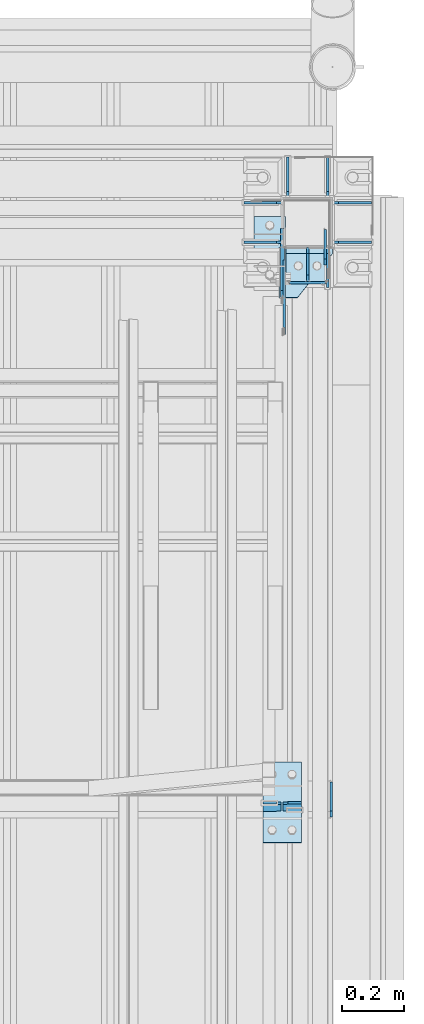
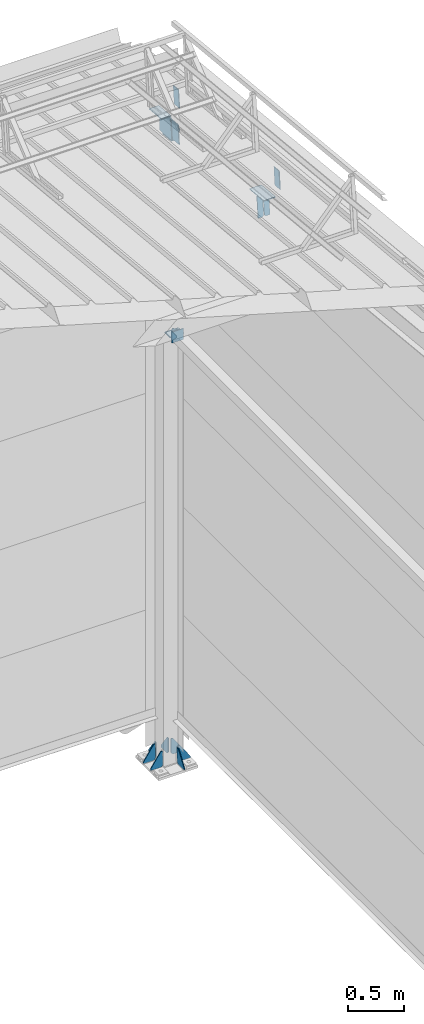
# One storey, part 167 of 709: 21 plates, 5 elements without a shape of their own.
"""IFC4 building model written with IfcOpenShell, lengths in millimetres."""

from ifc_helpers import new_model, si_unit, direction, frame, origin_with_axes, place, context, subcontext, project, spatial, line, indexed_curve, outline, extrude, material, element, aggregate, save


model = new_model("IFC4")

# Units and contexts
model_context = context("Model", 3, precision=0.2, world=origin_with_axes(), true_north=direction((0.0, 1.0)))
body_context = subcontext(model_context, "Body", "Model", "MODEL_VIEW")
ifc_project = project(units=[si_unit("LENGTHUNIT", "METRE", prefix="MILLI"), si_unit("AREAUNIT", "SQUARE_METRE"), si_unit("VOLUMEUNIT", "CUBIC_METRE"), si_unit("MASSUNIT", "GRAM", prefix="KILO"), si_unit("TIMEUNIT", "SECOND"), si_unit("PLANEANGLEUNIT", "RADIAN"), si_unit("SOLIDANGLEUNIT", "STERADIAN"), si_unit("THERMODYNAMICTEMPERATUREUNIT", "DEGREE_CELSIUS"), si_unit("LUMINOUSINTENSITYUNIT", "LUMEN")], contexts=[model_context])

# Site, building, storey
site_placement = place(None, origin_with_axes())
site = spatial("IfcSite", under=ifc_project, at=site_placement, CompositionType="ELEMENT")
building_placement = place(site_placement, origin_with_axes())
building = spatial("IfcBuilding", under=site, at=building_placement, Name="Undefined", CompositionType="ELEMENT")
storey_placement = place(building_placement, origin_with_axes())
storey = spatial("IfcBuildingStorey", under=building, at=storey_placement, Name="Undefined", CompositionType="ELEMENT", Elevation=0.0)

# Assembly, plates
assembly_1_placement = place(storey_placement, frame((49920.0, 21920.0, -200.0), z_axis=(0.0, -1.0, 0.0), x_axis=(0.0, 0.0, 1.0)))
assembly_1 = element("IfcElementAssembly", 1, at=assembly_1_placement, inside=storey)
ifc_material = material(Name="C355-6", Category="STEEL")
plate_1_placement = place(assembly_1_placement, frame((4798.0, 0.0, 180.0), z_axis=(0.0, -1.0, 0.0), x_axis=(-1.0, 0.0, 0.0)))
plate_1 = element("IfcPlate", 2, at=plate_1_placement, material=ifc_material, ObjectType="499", context=body_context, shape_type="SolidModel", body=[
    extrude(outline(indexed_curve([(0.0, 0.0), (20.0, 0.0), (100.0, 80.0), (100.0, 100.0), (0.0, 100.0)], segments=[line(1, 2, 3, 4, 5, 1)])), frame((0.0, 0.0, 4.0), z_axis=(0.0, 0.0, 1.0), x_axis=(1.0, 0.0, 0.0)), (0.0, 0.0, -1.0), 8.0),
])
plate_2_placement = place(assembly_1_placement, frame((4802.0, -70.0, 80.0), z_axis=(1.0, 0.0, 0.0), x_axis=(0.0, 1.0, 0.0)))
plate_2 = element("IfcPlate", 3, at=plate_2_placement, material=ifc_material, ObjectType="504", context=body_context, shape_type="SolidModel", body=[
    extrude(outline(indexed_curve([(0.0, 0.0), (140.0, 0.0), (140.0, 100.0), (0.0, 100.0)], segments=[line(1, 2, 3, 4, 1)])), frame((0.0, 0.0, 4.0), z_axis=(0.0, 0.0, 1.0), x_axis=(1.0, 0.0, 0.0)), (0.0, 0.0, -1.0), 8.0),
])
plate_3_placement = place(assembly_1_placement, frame((25.0, -64.0, 80.0), z_axis=(0.0, -1.0, 0.0), x_axis=(1.0, 0.0, 0.0)))
plate_3 = element("IfcPlate", 4, at=plate_3_placement, material=ifc_material, ObjectType="430", context=body_context, shape_type="SolidModel", body=[
    extrude(outline(indexed_curve([(0.0, 20.0), (20.0, 0.0), (175.0, 0.0), (175.0, 20.0), (20.0, 130.0), (0.0, 130.0)], segments=[line(1, 2, 3, 4, 5, 6, 1)])), frame((0.0, 0.0, 4.0), z_axis=(0.0, 0.0, 1.0), x_axis=(1.0, 0.0, 0.0)), (0.0, 0.0, -1.0), 8.0),
])
plate_4_placement = place(assembly_1_placement, frame((25.0, 64.0, -80.0), z_axis=(0.0, 1.0, 0.0), x_axis=(1.0, 0.0, 0.0)))
plate_4 = element("IfcPlate", 5, at=plate_4_placement, material=ifc_material, ObjectType="430", context=body_context, shape_type="SolidModel", body=[
    extrude(outline(indexed_curve([(0.0, 20.0), (20.0, 0.0), (175.0, 0.0), (175.0, 20.0), (20.0, 130.0), (0.0, 130.0)], segments=[line(1, 2, 3, 4, 5, 6, 1)])), frame((0.0, 0.0, 4.0), z_axis=(0.0, 0.0, 1.0), x_axis=(1.0, 0.0, 0.0)), (0.0, 0.0, -1.0), 8.0),
])
plate_5_placement = place(assembly_1_placement, frame((25.0, 205.0, 64.0), z_axis=(0.0, 0.0, 1.0), x_axis=(0.0, -1.0, 0.0)))
plate_5 = element("IfcPlate", 6, at=plate_5_placement, material=ifc_material, ObjectType="431", context=body_context, shape_type="SolidModel", body=[
    extrude(outline(indexed_curve([(0.0, 0.0), (105.0, 0.0), (125.0, 20.0), (125.0, 175.0), (105.0, 175.0), (0.0, 20.0)], segments=[line(1, 2, 3, 4, 5, 6, 1)])), frame((0.0, 0.0, 4.0), z_axis=(0.0, 0.0, 1.0), x_axis=(1.0, 0.0, 0.0)), (0.0, 0.0, -1.0), 8.0),
])
plate_6_placement = place(assembly_1_placement, frame((25.0, -80.0, 64.0), z_axis=(0.0, 0.0, 1.0), x_axis=(0.0, -1.0, 0.0)))
plate_6 = element("IfcPlate", 7, at=plate_6_placement, material=ifc_material, ObjectType="431", context=body_context, shape_type="SolidModel", body=[
    extrude(outline(indexed_curve([(0.0, 20.0), (20.0, 0.0), (125.0, 0.0), (125.0, 20.0), (20.0, 175.0), (0.0, 175.0)], segments=[line(1, 2, 3, 4, 5, 6, 1)])), frame((0.0, 0.0, 4.0), z_axis=(0.0, 0.0, 1.0), x_axis=(1.0, 0.0, 0.0)), (0.0, 0.0, -1.0), 8.0),
])
plate_7_placement = place(assembly_1_placement, frame((25.0, 205.0, -64.0), z_axis=(0.0, 0.0, 1.0), x_axis=(0.0, -1.0, 0.0)))
plate_7 = element("IfcPlate", 8, at=plate_7_placement, material=ifc_material, ObjectType="431", context=body_context, shape_type="SolidModel", body=[
    extrude(outline(indexed_curve([(0.0, 0.0), (105.0, 0.0), (125.0, 20.0), (125.0, 175.0), (105.0, 175.0), (0.0, 20.0)], segments=[line(1, 2, 3, 4, 5, 6, 1)])), frame((0.0, 0.0, 4.0), z_axis=(0.0, 0.0, 1.0), x_axis=(1.0, 0.0, 0.0)), (0.0, 0.0, -1.0), 8.0),
])
plate_8_placement = place(assembly_1_placement, frame((25.0, -64.0, -80.0), z_axis=(0.0, 1.0, 0.0), x_axis=(1.0, 0.0, 0.0)))
plate_8 = element("IfcPlate", 9, at=plate_8_placement, material=ifc_material, ObjectType="430", context=body_context, shape_type="SolidModel", body=[
    extrude(outline(indexed_curve([(0.0, 20.0), (20.0, 0.0), (175.0, 0.0), (175.0, 20.0), (20.0, 130.0), (0.0, 130.0)], segments=[line(1, 2, 3, 4, 5, 6, 1)])), frame((0.0, 0.0, 4.0), z_axis=(0.0, 0.0, 1.0), x_axis=(1.0, 0.0, 0.0)), (0.0, 0.0, -1.0), 8.0),
])
plate_9_placement = place(assembly_1_placement, frame((25.0, -80.0, -64.0), z_axis=(0.0, 0.0, 1.0), x_axis=(0.0, -1.0, 0.0)))
plate_9 = element("IfcPlate", 10, at=plate_9_placement, material=ifc_material, ObjectType="431", context=body_context, shape_type="SolidModel", body=[
    extrude(outline(indexed_curve([(0.0, 20.0), (20.0, 0.0), (125.0, 0.0), (125.0, 20.0), (20.0, 175.0), (0.0, 175.0)], segments=[line(1, 2, 3, 4, 5, 6, 1)])), frame((0.0, 0.0, 4.0), z_axis=(0.0, 0.0, 1.0), x_axis=(1.0, 0.0, 0.0)), (0.0, 0.0, -1.0), 8.0),
])
plate_10_placement = place(assembly_1_placement, frame((7241.79623, 81.0, 218.70769), z_axis=(0.0, -1.0, 0.0), x_axis=(-0.9950371902, 0.0, 0.099503719)))
plate_10 = element("IfcPlate", 11, at=plate_10_placement, material=ifc_material, ObjectType="455", context=body_context, shape_type="SolidModel", body=[
    extrude(outline(indexed_curve([(0.0, 0.0), (232.0397, 0.0), (232.0397, 162.60347), (226.06948, 222.3057), (0.0, 199.69876)], segments=[line(1, 2, 3, 4, 5, 1)])), frame((0.0, 0.0, 6.0), z_axis=(0.0, 0.0, 1.0), x_axis=(1.0, 0.0, 0.0)), (0.0, 0.0, -1.0), 12.0),
])
plate_11_placement = place(assembly_1_placement, frame((7006.92795, 92.0, 242.19452), z_axis=(-0.9950371902, 0.0, 0.099503719), x_axis=(-0.099503719, 0.0, -0.9950371902)))
plate_11 = element("IfcPlate", 12, at=plate_11_placement, material=ifc_material, ObjectType="456", context=body_context, shape_type="SolidModel", body=[
    extrude(outline(indexed_curve([(0.0, 0.0), (162.60347, 0.0), (162.60347, 172.0), (142.60347, 172.0), (0.0, 59.5)], segments=[line(1, 2, 3, 4, 5, 1)])), frame((0.0, 0.0, 4.0), z_axis=(0.0, 0.0, 1.0), x_axis=(1.0, 0.0, 0.0)), (0.0, 0.0, -1.0), 8.0),
])
aggregate(assembly_1, [plate_1, plate_2, plate_3, plate_4, plate_5, plate_6, plate_7, plate_8, plate_9, plate_10, plate_11])

assembly_2_placement = place(storey_placement, frame((49837.5, 21654.0, 6929.907), z_axis=(-1.0, 0.0, 0.0), x_axis=(0.0, -0.9950371902, 0.099503719)))
assembly_2 = element("IfcElementAssembly", 13, at=assembly_2_placement, inside=storey)
plate_12_placement = place(assembly_2_placement, frame((1621.78359, 115.0, 62.0), z_axis=(-1.0, 0.0, 0.0), x_axis=(0.0, 0.0, -1.0)))
plate_12 = element("IfcPlate", 14, at=plate_12_placement, material=ifc_material, ObjectType="594", context=body_context, shape_type="SolidModel", body=[
    extrude(outline(indexed_curve([(0.0, 0.0), (43.5, 0.0), (58.5, 15.0), (58.5, 215.0), (43.5, 230.0), (0.0, 230.0)], segments=[line(1, 2, 3, 4, 5, 6, 1)])), frame((0.0, 0.0, 4.0), z_axis=(0.0, 0.0, 1.0), x_axis=(1.0, 0.0, 0.0)), (0.0, 0.0, -1.0), 8.0),
])
plate_13_placement = place(assembly_2_placement, frame((1621.78359, -115.0, -62.0), z_axis=(-1.0, 0.0, 0.0), x_axis=(0.0, 0.0, 1.0)))
plate_13 = element("IfcPlate", 15, at=plate_13_placement, material=ifc_material, ObjectType="594", context=body_context, shape_type="SolidModel", body=[
    extrude(outline(indexed_curve([(0.0, 0.0), (43.5, 0.0), (58.5, 15.0), (58.5, 215.0), (43.5, 230.0), (0.0, 230.0)], segments=[line(1, 2, 3, 4, 5, 6, 1)])), frame((0.0, 0.0, 4.0), z_axis=(0.0, 0.0, 1.0), x_axis=(1.0, 0.0, 0.0)), (0.0, 0.0, -1.0), 8.0),
])
plate_14_placement = place(assembly_2_placement, frame((84.87182, 105.0, -6.5), z_axis=(0.0, 0.0, -1.0), x_axis=(0.0, -1.0, 0.0)))
plate_14 = element("IfcPlate", 16, at=plate_14_placement, material=ifc_material, ObjectType="453", context=body_context, shape_type="SolidModel", body=[
    extrude(outline(indexed_curve([(0.0, 0.0), (210.0, 0.0), (210.0, 220.0), (0.0, 220.0)], segments=[line(1, 2, 3, 4, 1)])), frame((0.0, 0.0, 4.0), z_axis=(0.0, 0.0, 1.0), x_axis=(1.0, 0.0, 0.0)), (0.0, 0.0, -1.0), 8.0),
])
aggregate(assembly_2, [plate_12, plate_13, plate_14])

assembly_3_placement = place(storey_placement, frame((49920.0, 16500.0, 4610.0), z_axis=(0.0, 0.0, -1.0), x_axis=(0.0, 1.0, 0.0)))
assembly_3 = element("IfcElementAssembly", 17, at=assembly_3_placement, inside=storey)
plate_15_placement = place(assembly_3_placement, frame((5230.0, 70.0, 0.0), z_axis=(0.0, 0.0, -1.0), x_axis=(1.0, 0.0, 0.0)))
plate_15 = element("IfcPlate", 18, at=plate_15_placement, material=ifc_material, ObjectType="497", context=body_context, shape_type="SolidModel", body=[
    extrude(outline(indexed_curve([(0.0, 0.0), (90.0, 0.0), (90.0, 140.0), (0.0, 140.0)], segments=[line(1, 2, 3, 4, 1)])), frame((0.0, 0.0, 4.0), z_axis=(0.0, 0.0, 1.0), x_axis=(1.0, 0.0, 0.0)), (0.0, 0.0, -1.0), 8.0),
])
plate_16_placement = place(assembly_3_placement, frame((5226.0, 60.0, -60.0), z_axis=(1.0, 0.0, 0.0), x_axis=(0.0, 0.0, 1.0)))
plate_16 = element("IfcPlate", 19, at=plate_16_placement, material=ifc_material, ObjectType="503", context=body_context, shape_type="SolidModel", body=[
    extrude(outline(indexed_curve([(0.0, 0.0), (120.0, 0.0), (120.0, 120.0), (0.0, 120.0)], segments=[line(1, 2, 3, 4, 1)])), frame((0.0, 0.0, 4.0), z_axis=(0.0, 0.0, 1.0), x_axis=(1.0, 0.0, 0.0)), (0.0, 0.0, -1.0), 8.0),
])
plate_17_placement = place(assembly_3_placement, frame((5230.0, 0.0, -60.0), z_axis=(0.0, -1.0, 0.0), x_axis=(1.0, 0.0, 0.0)))
plate_17 = element("IfcPlate", 20, at=plate_17_placement, material=ifc_material, ObjectType="498", context=body_context, shape_type="SolidModel", body=[
    extrude(outline(indexed_curve([(0.0, 0.0), (20.0, 0.0), (90.0, 36.0), (90.0, 56.0), (0.0, 56.0)], segments=[line(1, 2, 3, 4, 5, 1)])), frame((0.0, 0.0, 4.0), z_axis=(0.0, 0.0, 1.0), x_axis=(1.0, 0.0, 0.0)), (0.0, 0.0, -1.0), 8.0),
])
aggregate(assembly_3, [plate_15, plate_16, plate_17])

assembly_4_placement = place(storey_placement, frame((50000.0, 20063.34988, 7322.12913), z_axis=(0.0, -0.9950371902, 0.099503719), x_axis=(-1.0, 0.0, 0.0)))
assembly_4 = element("IfcElementAssembly", 21, at=assembly_4_placement, inside=storey)
plate_18_placement = place(assembly_4_placement, frame((4.0, 97.0, 47.0), z_axis=(-1.0, 0.0, 0.0), x_axis=(0.0, 0.0, -1.0)))
plate_18 = element("IfcPlate", 22, at=plate_18_placement, material=ifc_material, ObjectType="592", context=body_context, shape_type="SolidModel", body=[
    extrude(outline(indexed_curve([(0.0, 0.0), (94.0, 0.0), (94.0, 194.0), (0.0, 194.0)], segments=[line(1, 2, 3, 4, 1)])), frame((0.0, 0.0, 4.0), z_axis=(0.0, 0.0, 1.0), x_axis=(1.0, 0.0, 0.0)), (0.0, 0.0, -1.0), 8.0),
])
plate_19_placement = place(assembly_4_placement, frame((100.5, 104.0, -130.0), z_axis=(0.0, 1.0, 0.0), x_axis=(0.0, 0.0, 1.0)))
plate_19 = element("IfcPlate", 23, at=plate_19_placement, material=ifc_material, ObjectType="593", context=body_context, shape_type="SolidModel", body=[
    extrude(outline(indexed_curve([(0.0, 0.0), (260.0, 0.0), (260.0, 124.0), (0.0, 124.0)], segments=[line(1, 2, 3, 4, 1)])), frame((0.0, 0.0, 4.0), z_axis=(0.0, 0.0, 1.0), x_axis=(1.0, 0.0, 0.0)), (0.0, 0.0, -1.0), 8.0),
])
aggregate(assembly_4, [plate_18, plate_19])

assembly_5_placement = place(storey_placement, frame((50000.0, 21840.04963, 7144.45915), z_axis=(0.0, -0.9950371902, 0.099503719), x_axis=(-1.0, 0.0, 0.0)))
assembly_5 = element("IfcElementAssembly", 24, at=assembly_5_placement, inside=storey)
plate_20_placement = place(assembly_5_placement, frame((24.0, 97.0, 47.0), z_axis=(-1.0, 0.0, 0.0), x_axis=(0.0, 0.0, -1.0)))
plate_20 = element("IfcPlate", 25, at=plate_20_placement, material=ifc_material, ObjectType="592", context=body_context, shape_type="SolidModel", body=[
    extrude(outline(indexed_curve([(0.0, 0.0), (94.0, 0.0), (94.0, 194.0), (0.0, 194.0)], segments=[line(1, 2, 3, 4, 1)])), frame((0.0, 0.0, 4.0), z_axis=(0.0, 0.0, 1.0), x_axis=(1.0, 0.0, 0.0)), (0.0, 0.0, -1.0), 8.0),
])
plate_21_placement = place(assembly_5_placement, frame((252.0, 104.0, 110.0), z_axis=(0.0, -1.0, 0.0), x_axis=(-1.0, 0.0, 0.0)))
plate_21 = element("IfcPlate", 26, at=plate_21_placement, material=ifc_material, ObjectType="591", context=body_context, shape_type="SolidModel", body=[
    extrude(outline(indexed_curve([(0.0, 0.0), (100.0, 0.0), (100.0, 220.0), (0.0, 220.0)], segments=[line(1, 2, 3, 4, 1)])), frame((0.0, 0.0, 4.0), z_axis=(0.0, 0.0, 1.0), x_axis=(1.0, 0.0, 0.0)), (0.0, 0.0, -1.0), 8.0),
])
aggregate(assembly_5, [plate_20, plate_21])

save(model, "model.ifc")
